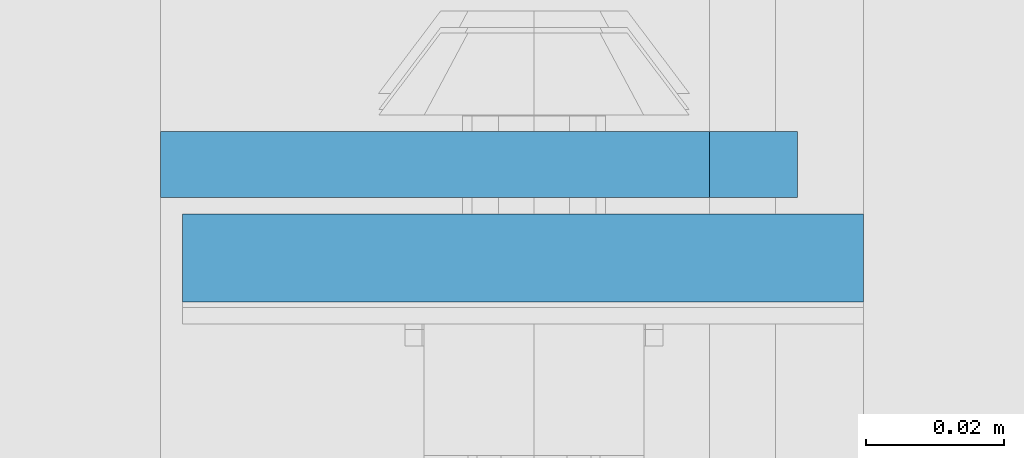
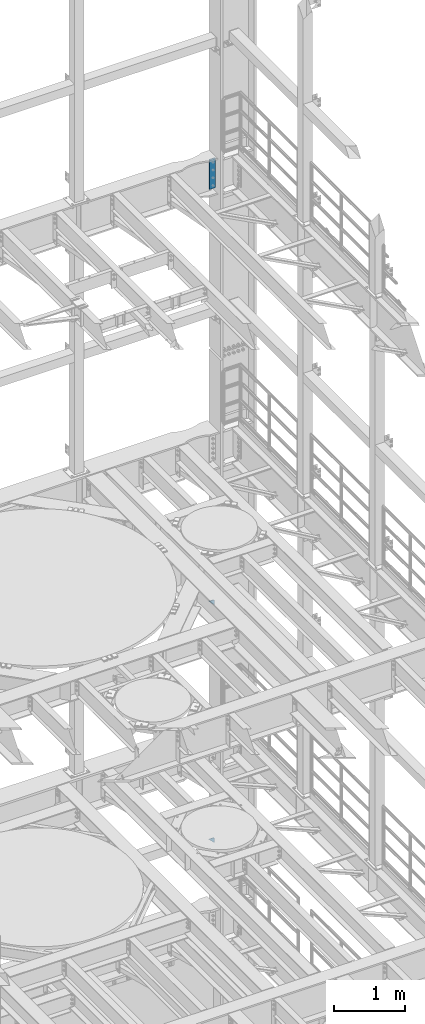
# One storey, part 1810 of 1876: 3 plates, 2 elements without a shape of their own.
"""IFC2X3 building model written with IfcOpenShell, lengths in millimetres."""

from ifc_helpers import new_model, si_unit, frame, origin_with_axes, place, context, subcontext, project, spatial, faceted_brep, material, type_object, element, aggregate, save


model = new_model("IFC2X3")

# Units and contexts
model_context = context("Model", 3, precision=1e-05, world=origin_with_axes())
body_context = subcontext(model_context, "Body", "Model", "MODEL_VIEW")
ifc_project = project(units=[si_unit("LENGTHUNIT", "METRE", prefix="MILLI"), si_unit("AREAUNIT", "SQUARE_METRE"), si_unit("VOLUMEUNIT", "CUBIC_METRE"), si_unit("MASSUNIT", "GRAM", prefix="KILO"), si_unit("TIMEUNIT", "SECOND"), si_unit("PLANEANGLEUNIT", "RADIAN"), si_unit("SOLIDANGLEUNIT", "STERADIAN"), si_unit("THERMODYNAMICTEMPERATUREUNIT", "DEGREE_CELSIUS"), si_unit("LUMINOUSINTENSITYUNIT", "LUMEN")], contexts=[model_context])

# Site, building, storey
site_placement = place(None, origin_with_axes())
site = spatial("IfcSite", under=ifc_project, at=site_placement, CompositionType="ELEMENT")
building_placement = place(site_placement, origin_with_axes())
building = spatial("IfcBuilding", under=site, at=building_placement, Name="Undefined", CompositionType="ELEMENT")
storey_placement = place(building_placement, origin_with_axes())
storey = spatial("IfcBuildingStorey", under=building, at=storey_placement, Name="Undefined", CompositionType="ELEMENT", Elevation=0.0)

# Assembly, plates
assembly_1_placement = place(storey_placement, origin_with_axes())
assembly_1 = element("IfcElementAssembly", 1, at=assembly_1_placement, inside=storey, Name="COLUMN", AssemblyPlace="NOTDEFINED", PredefinedType="RIGID_FRAME")
ifc_material_1 = material(Name="STEEL/A36")
plate_type_1 = type_object("IfcPlateType", PredefinedType="NOTDEFINED")
plate_1_placement = place(assembly_1_placement, frame((7226.29999940317, 13716.0, 6235.7), z_axis=(0.707106779186547, 0.0, 0.707106783186548), x_axis=(0.707106783186548, 4.99999675792934e-09, -0.707106779186547)))
plate_1 = element("IfcPlate", 2, at=plate_1_placement, type_object=plate_type_1, material=ifc_material_1, Name="PLATE", context=body_context, shape_type="Brep", body=[
    faceted_brep([(0.0, -4.76249999999982, 0.0), (56.1266013136901, -4.76249999997708, 56.1266013135391), (56.1266013136883, 4.76250000002256, 56.1266013135428), (0.0, 4.76249999999982, 0.0), (74.0871132860975, -4.7624999999698, 56.1266013135246), (74.0871132860993, 4.76250000002983, 56.1266013135282), (130.213714599717, -4.76249999994707, -1.30967237055302e-10), (130.213714599715, 4.76250000005257, -1.23691279441118e-10)], [[[0, 1, 2, 3]], [[1, 4, 5, 2]], [[4, 6, 7, 5]], [[6, 0, 3, 7]], [[5, 7, 3, 2]], [[6, 4, 1, 0]]]),
])
plate_2_placement = place(assembly_1_placement, frame((7226.29999940326, 13716.0, 10325.1), z_axis=(0.707106779186547, 0.0, 0.707106783186548), x_axis=(0.707106783186548, 4.99999675792934e-09, -0.707106779186547)))
plate_2 = element("IfcPlate", 3, at=plate_2_placement, type_object=plate_type_1, material=ifc_material_1, Name="PLATE", context=body_context, shape_type="Brep", body=[
    faceted_brep([(0.0, -4.76249999999982, 0.0), (56.1266013136901, -4.76249999997708, 56.1266013135391), (56.1266013136883, 4.76250000002256, 56.1266013135428), (0.0, 4.76249999999982, 0.0), (74.0871132860975, -4.7624999999698, 56.1266013135246), (74.0871132860993, 4.76250000002983, 56.1266013135282), (130.213714599717, -4.76249999994707, -1.30967237055302e-10), (130.213714599715, 4.76250000005257, -1.23691279441118e-10)], [[[0, 1, 2, 3]], [[1, 4, 5, 2]], [[4, 6, 7, 5]], [[6, 0, 3, 7]], [[5, 7, 3, 2]], [[6, 4, 1, 0]]]),
])
aggregate(assembly_1, [plate_1, plate_2])

# Assembly, plate
assembly_2_placement = place(storey_placement, origin_with_axes())
assembly_2 = element("IfcElementAssembly", 4, at=assembly_2_placement, inside=storey, Name="COLUMN", AssemblyPlace="NOTDEFINED", PredefinedType="RIGID_FRAME")
ifc_material_2 = material(Name="STEEL/A572-50")
plate_type_2 = type_object("IfcPlateType", PredefinedType="NOTDEFINED")
plate_3_placement = place(assembly_2_placement, frame((7327.9, 13702.5069998741, 17929.225), z_axis=(-1.0, 0.0, 0.0), x_axis=(0.0, 0.0, -1.0)))
plate_3 = element("IfcPlate", 5, at=plate_3_placement, type_object=plate_type_2, material=ifc_material_2, Name="PLATE", context=body_context, shape_type="Brep", body=[
    faceted_brep([(0.0, -6.35000000000036, 0.0), (0.0, -6.34999999999991, 98.4250030517578), (0.0, 6.34999999999991, 98.4250030517578), (0.0, 6.35000000000036, 0.0), (514.349975585938, -6.35000000000036, 98.4250030517578), (514.349975585938, 6.35000000000036, 98.4250030517578), (514.349975585938, -6.35000000000036, 0.0), (514.349975585938, 6.35000000000036, 0.0)], [[[0, 1, 2, 3]], [[1, 4, 5, 2]], [[4, 6, 7, 5]], [[6, 0, 3, 7]], [[5, 7, 3, 2]], [[6, 4, 1, 0]]]),
])
aggregate(assembly_2, [plate_3])

save(model, "model.ifc")
